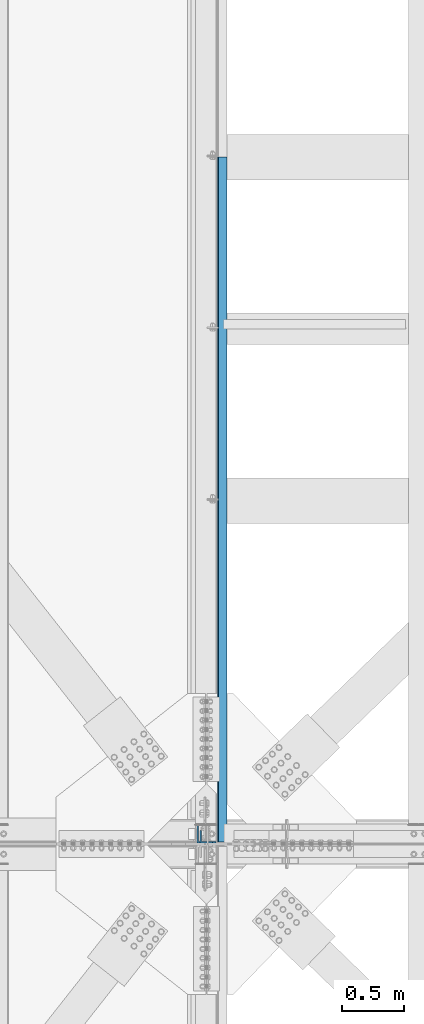
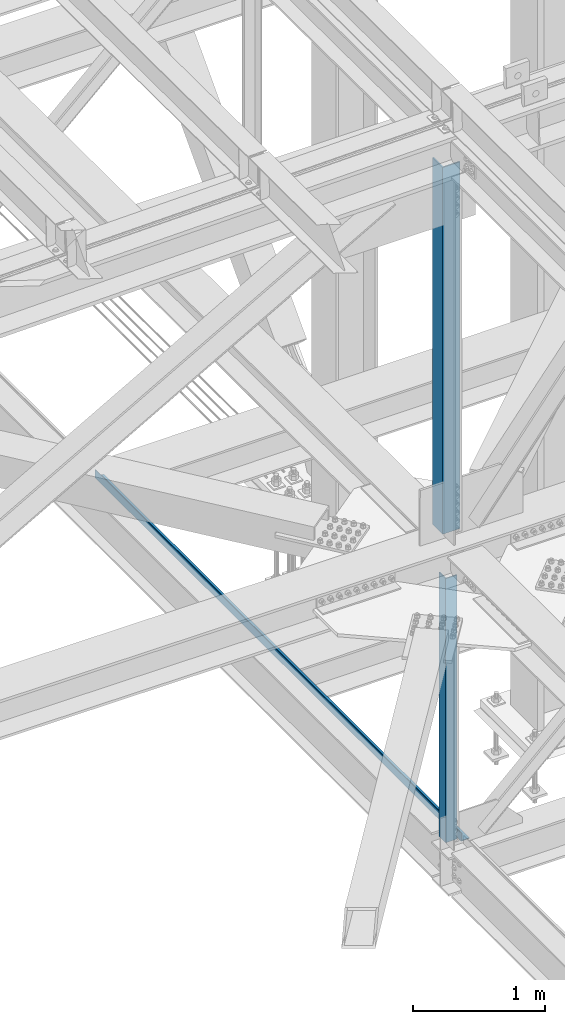
# One storey, part 1907 of 3843: 3 beams, 3 elements without a shape of their own.
"""IFC2X3 building model written with IfcOpenShell, lengths in millimetres."""

from ifc_helpers import new_model, si_unit, frame, origin_with_axes, place, context, subcontext, project, spatial, faceted_brep, material, type_object, element, aggregate, save


model = new_model("IFC2X3")

# Units and contexts
model_context = context("Model", 3, precision=1e-05, world=origin_with_axes())
body_context = subcontext(model_context, "Body", "Model", "MODEL_VIEW")
ifc_project = project(units=[si_unit("LENGTHUNIT", "METRE", prefix="MILLI"), si_unit("AREAUNIT", "SQUARE_METRE"), si_unit("VOLUMEUNIT", "CUBIC_METRE"), si_unit("MASSUNIT", "GRAM", prefix="KILO"), si_unit("TIMEUNIT", "SECOND"), si_unit("PLANEANGLEUNIT", "RADIAN"), si_unit("SOLIDANGLEUNIT", "STERADIAN"), si_unit("THERMODYNAMICTEMPERATUREUNIT", "DEGREE_CELSIUS"), si_unit("LUMINOUSINTENSITYUNIT", "LUMEN")], contexts=[model_context])

# Site, building, storey
site_placement = place(None, origin_with_axes())
site = spatial("IfcSite", under=ifc_project, at=site_placement, CompositionType="ELEMENT")
building_placement = place(site_placement, origin_with_axes())
building = spatial("IfcBuilding", under=site, at=building_placement, Name="Undefined", CompositionType="ELEMENT")
storey_placement = place(building_placement, origin_with_axes())
storey = spatial("IfcBuildingStorey", under=building, at=storey_placement, Name="Undefined", CompositionType="ELEMENT", Elevation=0.0)

# Assembly, beam
assembly_1_placement = place(storey_placement, origin_with_axes())
assembly_1 = element("IfcElementAssembly", 1, at=assembly_1_placement, inside=storey, Name="ANGLE", AssemblyPlace="NOTDEFINED", PredefinedType="RIGID_FRAME")
ifc_material_1 = material(Name="STEEL/A572-50")
beam_type_1 = type_object("IfcBeamType", Name="L4X4X3/8", PredefinedType="NOTDEFINED")
beam_1_placement = place(assembly_1_placement, frame((77012.8, 75688.825, 42319.6425242309), z_axis=(0.0, 1.0, 0.0), x_axis=(0.0, 0.0, -1.0)))
beam_1 = element("IfcBeam", 2, at=beam_1_placement, type_object=beam_type_1, material=ifc_material_1, Name="ANGLE", ObjectType="L4X4X3/8", context=body_context, shape_type="Brep", body=[
    faceted_brep([(209.620852803091, 50.8000000000029, -50.8000000000029), (209.620852803091, 50.8000000000029, 50.8000000000029), (2654.71094922173, 50.8000000000029, 50.8000000000029), (2654.71094922173, 50.8000000000029, -50.8000000000029), (209.620852803091, 41.2749999999942, 50.8000000000029), (2654.71094922173, 41.2749999999942, 50.8000000000029), (209.620852803091, 41.2749999999942, -41.2749999999942), (2654.71094922173, 41.2749999999942, -41.2749999999942), (209.620852803091, -50.8000000000029, -41.2749999999942), (2654.71094922173, -50.8000000000029, -41.2749999999942), (209.620852803091, -50.8000000000029, -50.8000000000029), (2654.71094922173, -50.8000000000029, -50.8000000000029)], [[[0, 1, 2, 3]], [[1, 4, 5, 2]], [[4, 6, 7, 5]], [[6, 8, 9, 7]], [[8, 10, 11, 9]], [[10, 0, 3, 11]], [[5, 7, 9, 11, 3, 2]], [[10, 8, 6, 4, 1, 0]]]),
])
aggregate(assembly_1, [beam_1])

assembly_2_placement = place(storey_placement, origin_with_axes())
assembly_2 = element("IfcElementAssembly", 3, at=assembly_2_placement, inside=storey, Name="BENT_PLATE", AssemblyPlace="NOTDEFINED", PredefinedType="RIGID_FRAME")
ifc_material_2 = material(Name="STEEL/A36")
beam_type_2 = type_object("IfcBeamType", PredefinedType="NOTDEFINED")
beam_2_placement = place(assembly_2_placement, frame((77179.4875000013, 78423.29375, 39627.1749999995), z_axis=(0.0, 1.0, 0.0), x_axis=(-1.0, 0.0, 0.0)))
beam_2 = element("IfcBeam", 4, at=beam_2_placement, type_object=beam_type_2, material=ifc_material_2, Name="BENT_PLATE", context=body_context, shape_type="Brep", body=[
    faceted_brep([(0.0, -3.17500000000291, -2776.53750000001), (0.0, -3.17500000000291, 2776.53750000001), (0.0, 3.17500000000291, 2776.53750000001), (0.0, 3.17500000000291, -2776.53750000001), (69.8500000010827, 3.17500000000291, 2776.53750000001), (69.8500000010827, 3.17500000000291, -2776.53750000001), (76.2000000010739, -3.17500000000291, -2776.53750000001), (76.2000000010739, -3.17500000000291, 2776.53750000001), (69.8500000011554, 73.0249999989392, 2776.53750000001), (69.8500000011554, 73.0249999989392, -2776.53750000001), (76.2000000011612, 73.0249999989246, 2776.53750000001), (76.2000000011612, 73.0249999989246, -2776.53750000001)], [[[0, 1, 2, 3]], [[3, 2, 4, 5]], [[1, 0, 6, 7]], [[5, 4, 8, 9]], [[4, 2, 1, 7, 10, 8]], [[7, 6, 11, 10]], [[6, 0, 3, 5, 9, 11]], [[10, 11, 9, 8]]]),
])
aggregate(assembly_2, [beam_2])

assembly_3_placement = place(storey_placement, origin_with_axes())
assembly_3 = element("IfcElementAssembly", 5, at=assembly_3_placement, inside=storey, Name="ANGLE", AssemblyPlace="NOTDEFINED", PredefinedType="RIGID_FRAME")
beam_type_3 = type_object("IfcBeamType", Name="L6X6X1/2", PredefinedType="NOTDEFINED")
beam_3_placement = place(assembly_3_placement, frame((77012.8, 75714.225, 46150.0389072731), z_axis=(0.0, 1.0, 0.0), x_axis=(0.0, 0.0, -1.0)))
beam_3 = element("IfcBeam", 6, at=beam_3_placement, type_object=beam_type_3, material=ifc_material_1, Name="ANGLE", ObjectType="L6X6X1/2", context=body_context, shape_type="Brep", body=[
    faceted_brep([(223.943368159584, 76.1999999999971, -76.1999999999971), (223.943368159584, 76.1999999999971, 76.1999999999971), (3620.00993423883, 76.1999999999971, 76.1999999999971), (3620.00993423883, 76.1999999999971, -76.1999999999971), (223.943368159584, 63.5, 76.1999999999971), (3620.00993423883, 63.5, 76.1999999999971), (223.943368159584, 63.5, -63.5), (3620.00993423883, 63.5, -63.5), (223.943368159584, -76.1999999999971, -63.5), (3620.00993423883, -76.1999999999971, -63.5), (223.943368159584, -76.1999999999971, -76.1999999999971), (3620.00993423883, -76.1999999999971, -76.1999999999971)], [[[0, 1, 2, 3]], [[1, 4, 5, 2]], [[4, 6, 7, 5]], [[6, 8, 9, 7]], [[8, 10, 11, 9]], [[10, 0, 3, 11]], [[5, 7, 9, 11, 3, 2]], [[10, 8, 6, 4, 1, 0]]]),
])
aggregate(assembly_3, [beam_3])

save(model, "model.ifc")
